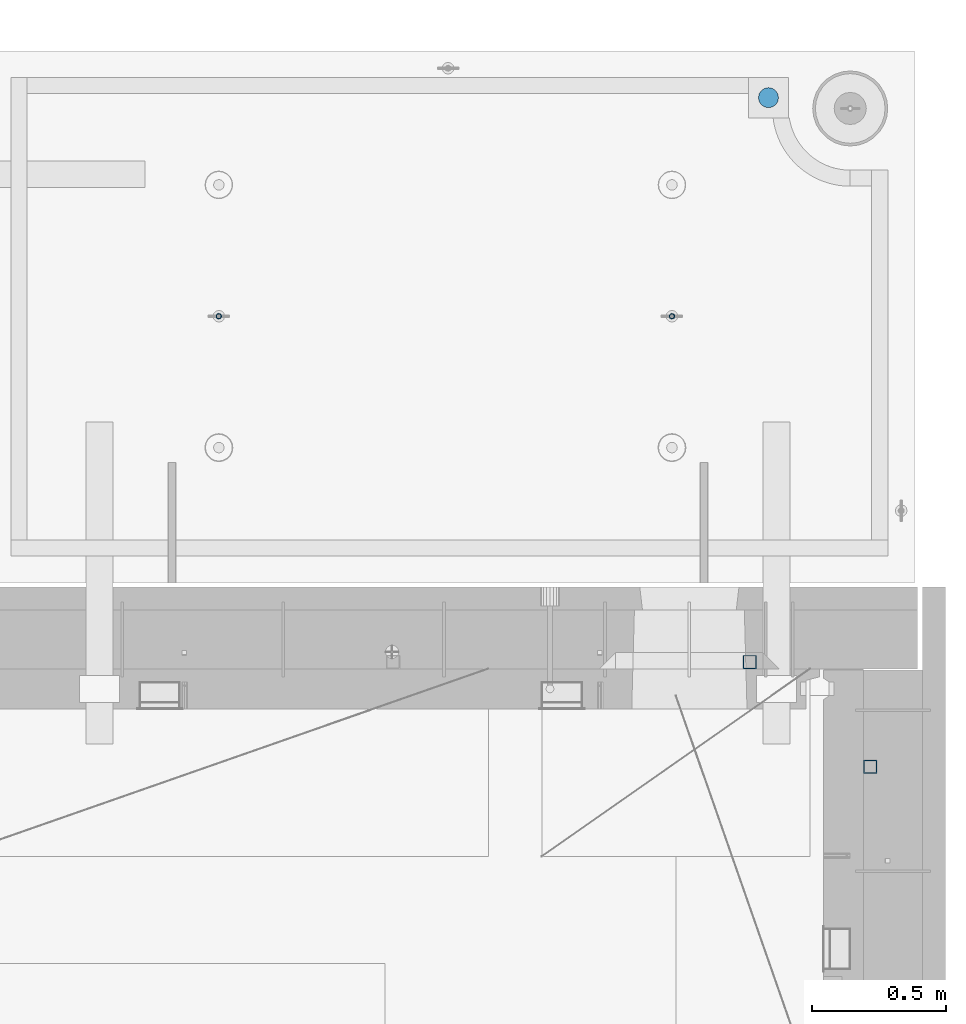
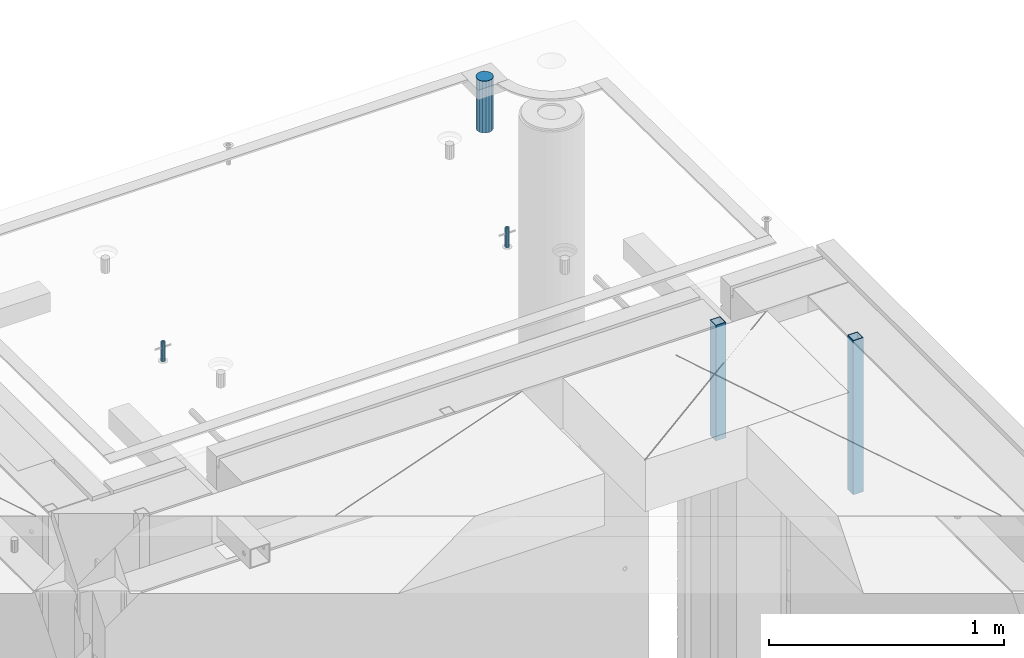
# One storey, part 36 of 341: 5 columns, 7 elements without a shape of their own.
"""IFC2X3 building model written with IfcOpenShell, lengths in millimetres."""

from ifc_helpers import new_model, si_unit, frame, origin_with_axes, place, context, subcontext, project, spatial, faceted_brep, material, type_object, element, aggregate, save


model = new_model("IFC2X3")

# Units and contexts
model_context = context("Model", 3, precision=1e-05, world=origin_with_axes())
body_context = subcontext(model_context, "Body", "Model", "MODEL_VIEW")
ifc_project = project(units=[si_unit("LENGTHUNIT", "METRE", prefix="MILLI"), si_unit("AREAUNIT", "SQUARE_METRE"), si_unit("VOLUMEUNIT", "CUBIC_METRE"), si_unit("MASSUNIT", "GRAM", prefix="KILO"), si_unit("TIMEUNIT", "SECOND"), si_unit("PLANEANGLEUNIT", "RADIAN"), si_unit("SOLIDANGLEUNIT", "STERADIAN"), si_unit("THERMODYNAMICTEMPERATUREUNIT", "DEGREE_CELSIUS"), si_unit("LUMINOUSINTENSITYUNIT", "LUMEN")], contexts=[model_context])

# Site, building, storey
site_placement = place(None, origin_with_axes())
site = spatial("IfcSite", under=ifc_project, at=site_placement, CompositionType="ELEMENT")
building_placement = place(site_placement, origin_with_axes())
building = spatial("IfcBuilding", under=site, at=building_placement, CompositionType="ELEMENT")
storey_placement = place(building_placement, origin_with_axes())
storey = spatial("IfcBuildingStorey", under=building, at=storey_placement, Name="5", CompositionType="ELEMENT", Elevation=0.0)

# Assemblies, column
assembly_1_placement = place(storey_placement, origin_with_axes())
assembly_1 = element("IfcElementAssembly", 1, at=assembly_1_placement, inside=storey, AssemblyPlace="NOTDEFINED", PredefinedType="REINFORCEMENT_UNIT")
assembly_2_placement = place(assembly_1_placement, origin_with_axes())
assembly_2 = element("IfcElementAssembly", 2, at=assembly_2_placement, Name="Steel Assembly", AssemblyPlace="NOTDEFINED", PredefinedType="RIGID_FRAME")
aggregate(assembly_1, [assembly_2])
ifc_material_1 = material(Name="STEEL/S355J2")
column_type_1 = type_object("IfcColumnType", Name="50X50X3", PredefinedType="NOTDEFINED")
column_1_placement = place(assembly_2_placement, frame((34635.0, 20605.0, 96140.0), z_axis=(1.0, 0.0, 0.0), x_axis=(0.0, 0.0, 1.0)))
column_1 = element("IfcColumn", 3, at=column_1_placement, type_object=column_type_1, material=ifc_material_1, ObjectType="50X50X3", context=body_context, shape_type="Brep", body=[
    faceted_brep([(0.0, 22.0, -22.0), (0.0, -22.0, -22.0), (600.0, -22.0, -22.0), (600.0, 22.0, -22.0), (0.0, -22.0, 22.0), (600.0, -22.0, 22.0), (0.0, 22.0, 22.0), (600.0, 22.0, 22.0), (0.0, 25.0, -25.0), (0.0, 25.0, 25.0), (600.0, 25.0, 25.0), (600.0, 25.0, -25.0), (0.0, -25.0, 25.0), (600.0, -25.0, 25.0), (0.0, -25.0, -25.0), (600.0, -25.0, -25.0)], [[[0, 1, 2, 3]], [[1, 4, 5, 2]], [[4, 6, 7, 5]], [[6, 0, 3, 7]], [[8, 9, 10, 11]], [[9, 12, 13, 10]], [[12, 14, 15, 13]], [[14, 8, 11, 15]], [[13, 15, 11, 10], [5, 7, 3, 2]], [[14, 12, 9, 8], [6, 4, 1, 0]]]),
])
aggregate(assembly_2, [column_1])

assembly_3_placement = place(storey_placement, origin_with_axes())
assembly_3 = element("IfcElementAssembly", 4, at=assembly_3_placement, inside=storey, AssemblyPlace="NOTDEFINED", PredefinedType="REINFORCEMENT_UNIT")
assembly_4_placement = place(assembly_3_placement, origin_with_axes())
assembly_4 = element("IfcElementAssembly", 5, at=assembly_4_placement, Name="Steel Assembly", AssemblyPlace="NOTDEFINED", PredefinedType="RIGID_FRAME")
aggregate(assembly_3, [assembly_4])
column_2_placement = place(assembly_4_placement, frame((35085.0, 20215.0002861023, 95940.0), z_axis=(0.0, -1.0, 0.0), x_axis=(0.0, 0.0, 1.0)))
column_2 = element("IfcColumn", 6, at=column_2_placement, type_object=column_type_1, material=ifc_material_1, ObjectType="50X50X3", context=body_context, shape_type="Brep", body=[
    faceted_brep([(0.0, 22.0, -22.0), (0.0, -22.0, -22.0), (800.0, -22.0, -22.0), (800.0, 22.0, -22.0), (0.0, -22.0, 22.0), (800.0, -22.0, 22.0), (0.0, 22.0, 22.0), (800.0, 22.0, 22.0), (0.0, 25.0, -25.0), (0.0, 25.0, 25.0), (800.0, 25.0, 25.0), (800.0, 25.0, -25.0), (0.0, -25.0, 25.0), (800.0, -25.0, 25.0), (0.0, -25.0, -25.0), (800.0, -25.0, -25.0)], [[[0, 1, 2, 3]], [[1, 4, 5, 2]], [[4, 6, 7, 5]], [[6, 0, 3, 7]], [[8, 9, 10, 11]], [[9, 12, 13, 10]], [[12, 14, 15, 13]], [[14, 8, 11, 15]], [[13, 15, 11, 10], [5, 7, 3, 2]], [[14, 12, 9, 8], [6, 4, 1, 0]]]),
])
aggregate(assembly_4, [column_2])

# Assemblies, columns
assembly_5_placement = place(storey_placement, origin_with_axes())
assembly_5 = element("IfcElementAssembly", 7, at=assembly_5_placement, inside=storey, AssemblyPlace="NOTDEFINED", PredefinedType="REINFORCEMENT_UNIT")
assembly_6_placement = place(assembly_5_placement, origin_with_axes())
assembly_6 = element("IfcElementAssembly", 8, at=assembly_6_placement, Name="Steel Assembly", AssemblyPlace="NOTDEFINED", PredefinedType="RIGID_FRAME")
ifc_material_2 = material(Name="STEEL/1.4301")
column_type_2 = type_object("IfcColumnType", PredefinedType="NOTDEFINED")
column_3_placement = place(assembly_6_placement, frame((32654.9901431868, 21895.0034426477, 96445.0), z_axis=(0.000321686000089053, -0.999999948259057, 0.0), x_axis=(0.0, 0.0, 1.0)))
column_3 = element("IfcColumn", 9, at=column_3_placement, type_object=column_type_2, material=ifc_material_2, context=body_context, shape_type="Brep", body=[
    faceted_brep([(0.0, -8.0, 0.0), (0.0, -6.92820323027263, 4.0), (100.000000000029, -6.92820323027263, 4.0), (100.000000000029, -7.99999999999636, 0.0), (0.0, -4.0, 6.92820323027627), (100.000000000029, -4.0, 6.92820323027536), (0.0, 0.0, 8.0), (100.000000000029, 3.63797880709171e-12, 8.0), (0.0, 4.0, 6.92820323027627), (100.000000000029, 4.0, 6.92820323027536), (0.0, 6.92820323027263, 4.0), (100.000000000029, 6.92820323027627, 3.99999999999909), (0.0, 8.0, 0.0), (100.000000000029, 8.0, 0.0), (0.0, 6.92820323027263, -4.0), (100.000000000029, 6.92820323027627, -4.00000000000091), (0.0, 4.0, -6.92820323027627), (100.000000000029, 4.00000000000364, -6.92820323027536), (0.0, 0.0, -8.0), (100.000000000029, 3.63797880709171e-12, -8.00000000000091), (0.0, -4.0, -6.92820323027627), (100.000000000029, -3.99999999999636, -6.92820323027627), (0.0, -6.92820323027263, -4.0), (100.000000000029, -6.92820323027263, -4.0), (0.0, -10.4999999999927, -1.45519152283669e-11), (0.0, -9.09326673972828, -5.25000000001455), (100.000000000262, -9.09326673972828, -5.25000000001455), (100.000000000262, -10.4999999999927, -1.45519152283669e-11), (0.0, -5.24999999998545, -9.09326673974283), (100.000000000262, -5.24999999998545, -9.09326673974283), (0.0, 7.27595761418343e-12, -10.5), (100.000000000262, 7.27595761418343e-12, -10.5), (0.0, 5.25000000001455, -9.09326673975738), (100.000000000262, 5.25000000001455, -9.09326673975738), (0.0, 9.09326673975011, -5.25000000001455), (100.000000000262, 9.09326673975011, -5.25000000001455), (0.0, 10.5000000000073, -1.45519152283669e-11), (100.000000000262, 10.5000000000073, -1.45519152283669e-11), (0.0, 9.09326673975011, 5.25), (100.000000000262, 9.09326673975011, 5.25), (0.0, 5.25000000000728, 9.09326673972828), (100.000000000262, 5.25000000000728, 9.09326673972828), (0.0, 1.45519152283669e-11, 10.4999999999854), (100.000000000262, 1.45519152283669e-11, 10.4999999999854), (0.0, -5.24999999999272, 9.09326673972828), (100.000000000262, -5.24999999999272, 9.09326673972828), (0.0, -9.09326673972828, 5.24999999998545), (100.000000000262, -9.09326673972828, 5.24999999998545)], [[[0, 1, 2, 3]], [[1, 4, 5, 2]], [[4, 6, 7, 5]], [[6, 8, 9, 7]], [[8, 10, 11, 9]], [[10, 12, 13, 11]], [[12, 14, 15, 13]], [[14, 16, 17, 15]], [[16, 18, 19, 17]], [[18, 20, 21, 19]], [[20, 22, 23, 21]], [[22, 0, 3, 23]], [[24, 25, 26, 27]], [[25, 28, 29, 26]], [[28, 30, 31, 29]], [[30, 32, 33, 31]], [[32, 34, 35, 33]], [[34, 36, 37, 35]], [[36, 38, 39, 37]], [[38, 40, 41, 39]], [[40, 42, 43, 41]], [[42, 44, 45, 43]], [[44, 46, 47, 45]], [[46, 24, 27, 47]], [[29, 31, 33, 35, 37, 39, 41, 43, 45, 47, 27, 26], [5, 7, 9, 11, 13, 15, 17, 19, 21, 23, 3, 2]], [[46, 44, 42, 40, 38, 36, 34, 32, 30, 28, 25, 24], [22, 20, 18, 16, 14, 12, 10, 8, 6, 4, 1, 0]]]),
])
aggregate(assembly_6, [column_3])
assembly_7_placement = place(assembly_5_placement, origin_with_axes())
assembly_7 = element("IfcElementAssembly", 10, at=assembly_7_placement, Name="Steel Assembly", AssemblyPlace="NOTDEFINED", PredefinedType="RIGID_FRAME")
column_4_placement = place(assembly_7_placement, frame((34345.0001431868, 21895.0034426477, 96445.0), z_axis=(0.000321686000089053, -0.999999948259057, 0.0), x_axis=(0.0, 0.0, 1.0)))
column_4 = element("IfcColumn", 11, at=column_4_placement, type_object=column_type_2, material=ifc_material_2, context=body_context, shape_type="Brep", body=[
    faceted_brep([(0.0, -8.0, 0.0), (0.0, -6.92820323027263, 4.0), (100.000000000029, -6.92820323027263, 4.0), (100.000000000029, -7.99999999999636, 0.0), (0.0, -4.0, 6.92820323027627), (100.000000000029, -4.0, 6.92820323027536), (0.0, 0.0, 8.0), (100.000000000029, 3.63797880709171e-12, 8.0), (0.0, 4.0, 6.92820323027627), (100.000000000029, 4.0, 6.92820323027536), (0.0, 6.92820323027263, 4.0), (100.000000000029, 6.92820323027627, 3.99999999999909), (0.0, 8.0, 0.0), (100.000000000029, 8.0, 0.0), (0.0, 6.92820323027263, -4.0), (100.000000000029, 6.92820323027627, -4.00000000000091), (0.0, 4.0, -6.92820323027627), (100.000000000029, 4.00000000000364, -6.92820323027536), (0.0, 0.0, -8.0), (100.000000000029, 3.63797880709171e-12, -8.00000000000091), (0.0, -4.0, -6.92820323027627), (100.000000000029, -3.99999999999636, -6.92820323027627), (0.0, -6.92820323027263, -4.0), (100.000000000029, -6.92820323027263, -4.0), (0.0, -10.4999999999927, -1.45519152283669e-11), (0.0, -9.09326673972828, -5.25000000001455), (100.000000000262, -9.09326673972828, -5.25000000001455), (100.000000000262, -10.4999999999927, -1.45519152283669e-11), (0.0, -5.24999999998545, -9.09326673974283), (100.000000000262, -5.24999999998545, -9.09326673974283), (0.0, 7.27595761418343e-12, -10.5), (100.000000000262, 7.27595761418343e-12, -10.5), (0.0, 5.25000000001455, -9.09326673975738), (100.000000000262, 5.25000000001455, -9.09326673975738), (0.0, 9.09326673975011, -5.25000000001455), (100.000000000262, 9.09326673975011, -5.25000000001455), (0.0, 10.5000000000073, -1.45519152283669e-11), (100.000000000262, 10.5000000000073, -1.45519152283669e-11), (0.0, 9.09326673975011, 5.25), (100.000000000262, 9.09326673975011, 5.25), (0.0, 5.25000000000728, 9.09326673972828), (100.000000000262, 5.25000000000728, 9.09326673972828), (0.0, 1.45519152283669e-11, 10.4999999999854), (100.000000000262, 1.45519152283669e-11, 10.4999999999854), (0.0, -5.24999999999272, 9.09326673972828), (100.000000000262, -5.24999999999272, 9.09326673972828), (0.0, -9.09326673972828, 5.24999999998545), (100.000000000262, -9.09326673972828, 5.24999999998545)], [[[0, 1, 2, 3]], [[1, 4, 5, 2]], [[4, 6, 7, 5]], [[6, 8, 9, 7]], [[8, 10, 11, 9]], [[10, 12, 13, 11]], [[12, 14, 15, 13]], [[14, 16, 17, 15]], [[16, 18, 19, 17]], [[18, 20, 21, 19]], [[20, 22, 23, 21]], [[22, 0, 3, 23]], [[24, 25, 26, 27]], [[25, 28, 29, 26]], [[28, 30, 31, 29]], [[30, 32, 33, 31]], [[32, 34, 35, 33]], [[34, 36, 37, 35]], [[36, 38, 39, 37]], [[38, 40, 41, 39]], [[40, 42, 43, 41]], [[42, 44, 45, 43]], [[44, 46, 47, 45]], [[46, 24, 27, 47]], [[29, 31, 33, 35, 37, 39, 41, 43, 45, 47, 27, 26], [5, 7, 9, 11, 13, 15, 17, 19, 21, 23, 3, 2]], [[46, 44, 42, 40, 38, 36, 34, 32, 30, 28, 25, 24], [22, 20, 18, 16, 14, 12, 10, 8, 6, 4, 1, 0]]]),
])
aggregate(assembly_7, [column_4])
ifc_material_3 = material()
column_type_3 = type_object("IfcColumnType", Name="D75", PredefinedType="NOTDEFINED")
column_5_placement = place(assembly_5_placement, frame((34704.9998568133, 22710.1651093338, 96440.0), z_axis=(0.9999999949993, 0.000100007000000845, 0.0), x_axis=(0.0, 0.0, 1.0)))
column_5 = element("IfcColumn", 12, at=column_5_placement, type_object=column_type_3, material=ifc_material_3, ObjectType="D75", context=body_context, shape_type="Brep", body=[
    faceted_brep([(0.0, -37.4999999999991, 1.81898940354586e-12), (0.0, -34.6454824691718, -14.3506287136888), (270.0, -34.6454824691718, -14.3506287136888), (270.0, -37.4999999999991, 1.81898940354586e-12), (0.0, -26.5165042944936, -26.5165042944936), (270.0, -26.5165042944936, -26.5165042944936), (0.0, -14.3506287136906, -34.6454824691718), (270.0, -14.3506287136906, -34.6454824691718), (0.0, 9.09494701772928e-13, -37.4999999999982), (270.0, 9.09494701772928e-13, -37.4999999999982), (0.0, 14.3506287136915, -34.6454824691718), (270.0, 14.3506287136915, -34.6454824691718), (0.0, 26.5165042944973, -26.5165042944927), (270.0, 26.5165042944973, -26.5165042944927), (0.0, 34.6454824691746, -14.3506287136897), (270.0, 34.6454824691746, -14.3506287136897), (0.0, 37.5000000000018, 1.81898940354586e-12), (270.0, 37.5000000000018, 1.81898940354586e-12), (0.0, 34.6454824691755, 14.3506287136925), (270.0, 34.6454824691755, 14.3506287136925), (0.0, 26.5165042944964, 26.5165042944973), (270.0, 26.5165042944964, 26.5165042944973), (0.0, 14.3506287136934, 34.6454824691755), (270.0, 14.3506287136934, 34.6454824691755), (0.0, 1.81898940354586e-12, 37.5000000000027), (270.0, 1.81898940354586e-12, 37.5000000000027), (0.0, -14.3506287136897, 34.6454824691746), (270.0, -14.3506287136897, 34.6454824691746), (0.0, -26.5165042944946, 26.5165042944973), (270.0, -26.5165042944946, 26.5165042944973), (0.0, -34.6454824691718, 14.3506287136925), (270.0, -34.6454824691718, 14.3506287136925)], [[[0, 1, 2, 3]], [[1, 4, 5, 2]], [[4, 6, 7, 5]], [[6, 8, 9, 7]], [[8, 10, 11, 9]], [[10, 12, 13, 11]], [[12, 14, 15, 13]], [[14, 16, 17, 15]], [[16, 18, 19, 17]], [[18, 20, 21, 19]], [[20, 22, 23, 21]], [[22, 24, 25, 23]], [[24, 26, 27, 25]], [[26, 28, 29, 27]], [[28, 30, 31, 29]], [[30, 0, 3, 31]], [[5, 7, 9, 11, 13, 15, 17, 19, 21, 23, 25, 27, 29, 31, 3, 2]], [[30, 28, 26, 24, 22, 20, 18, 16, 14, 12, 10, 8, 6, 4, 1, 0]]]),
])
aggregate(assembly_5, [assembly_6, assembly_7, column_5])

save(model, "model.ifc")
